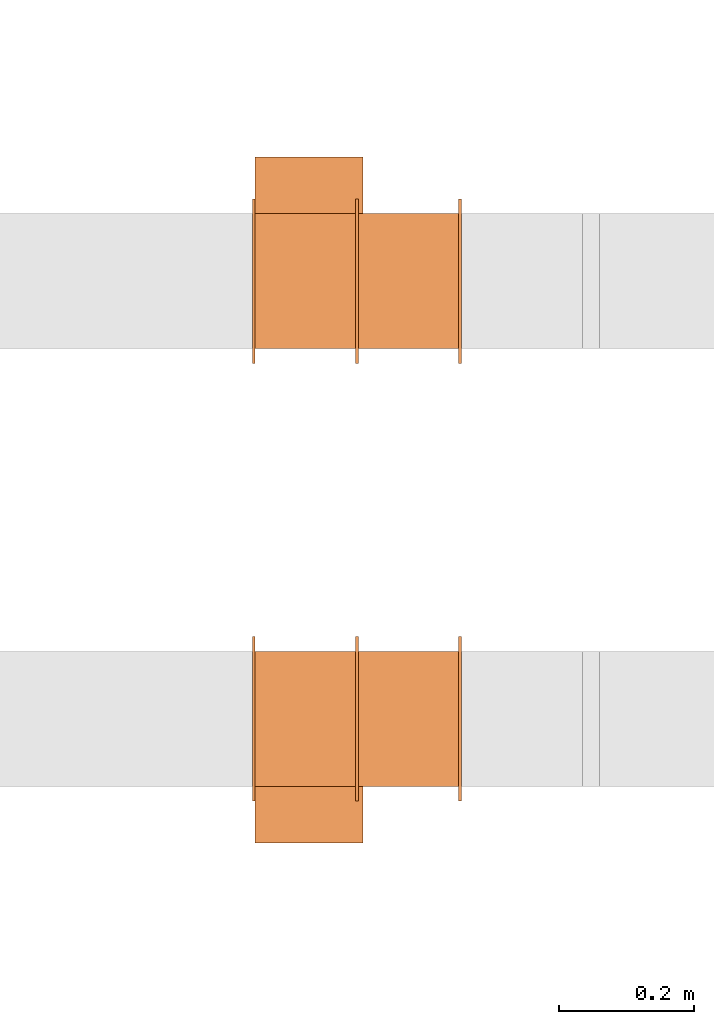
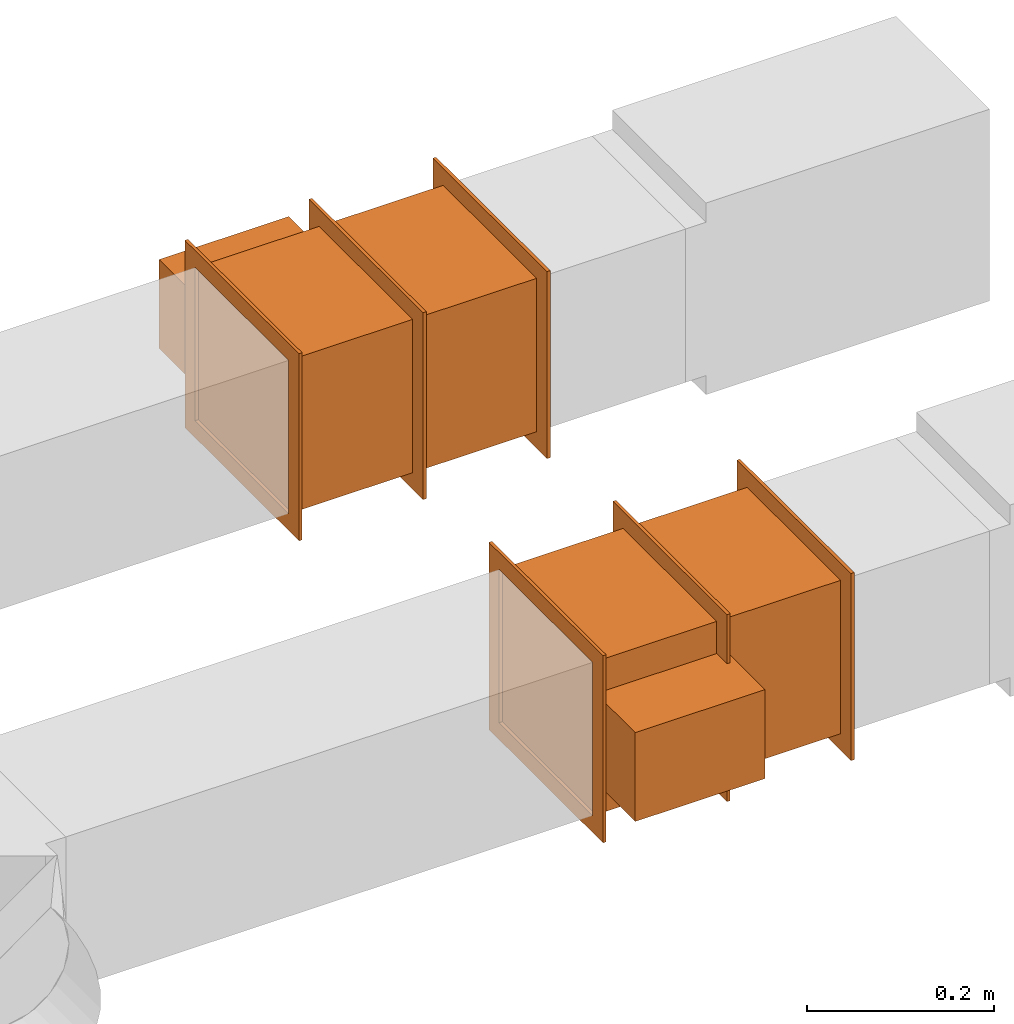
# One storey, part 12 of 12: 2 proxies.
"""IFC2X3 building model written with IfcOpenShell, lengths in millimetres."""

from ifc_helpers import new_model, entity, si_unit, converted_unit, derived_unit, direction, frame, frame_2d, origin, origin_2d_with_axis, place, context, subcontext, project, spatial, polyline, rectangle, outline, extrude, source, transform, mapped, type_object, type_shapes, element, save


model = new_model("IFC2X3")

# Units and contexts
model_context = context("Model", 3, precision=0.01, world=origin(), true_north=direction((6.12303176911189e-17, 1.0)))
body_context = subcontext(model_context, "Body", "Model", "MODEL_VIEW")
ifc_project = project(units=[si_unit("LENGTHUNIT", "METRE", prefix="MILLI"), si_unit("AREAUNIT", "SQUARE_METRE"), si_unit("VOLUMEUNIT", "CUBIC_METRE"), converted_unit("PLANEANGLEUNIT", "DEGREE", entity("IfcRatioMeasure", 0.0174532925199433), si_unit("PLANEANGLEUNIT", "RADIAN"), dimensions=[0, 0, 0, 0, 0, 0, 0]), si_unit("MASSUNIT", "GRAM", prefix="KILO"), derived_unit("MASSDENSITYUNIT", [(si_unit("MASSUNIT", "GRAM", prefix="KILO"), 1), (si_unit("LENGTHUNIT", "METRE"), -3)]), si_unit("TIMEUNIT", "SECOND"), si_unit("FREQUENCYUNIT", "HERTZ"), si_unit("THERMODYNAMICTEMPERATUREUNIT", "DEGREE_CELSIUS"), derived_unit("THERMALTRANSMITTANCEUNIT", [(si_unit("MASSUNIT", "GRAM", prefix="KILO"), 1), (si_unit("THERMODYNAMICTEMPERATUREUNIT", "KELVIN"), -1), (si_unit("TIMEUNIT", "SECOND"), -3)]), derived_unit("VOLUMETRICFLOWRATEUNIT", [(si_unit("LENGTHUNIT", "METRE"), 3), (si_unit("TIMEUNIT", "SECOND"), -1)]), si_unit("ELECTRICCURRENTUNIT", "AMPERE"), si_unit("ELECTRICVOLTAGEUNIT", "VOLT"), si_unit("POWERUNIT", "WATT"), si_unit("FORCEUNIT", "NEWTON", prefix="KILO"), si_unit("ILLUMINANCEUNIT", "LUX"), si_unit("LUMINOUSFLUXUNIT", "LUMEN"), si_unit("LUMINOUSINTENSITYUNIT", "CANDELA"), derived_unit("USERDEFINED", [(si_unit("MASSUNIT", "GRAM", prefix="KILO"), -1), (si_unit("LENGTHUNIT", "METRE"), -2), (si_unit("TIMEUNIT", "SECOND"), 3), (si_unit("LUMINOUSFLUXUNIT", "LUMEN"), 1)]), derived_unit("LINEARVELOCITYUNIT", [(si_unit("LENGTHUNIT", "METRE"), 1), (si_unit("TIMEUNIT", "SECOND"), -1)]), si_unit("PRESSUREUNIT", "PASCAL"), derived_unit("USERDEFINED", [(si_unit("LENGTHUNIT", "METRE"), -2), (si_unit("MASSUNIT", "GRAM", prefix="KILO"), 1), (si_unit("TIMEUNIT", "SECOND"), -2)])], contexts=[model_context])

# Site, building, storey
site_placement = place(None, origin())
site = spatial("IfcSite", under=ifc_project, at=site_placement, CompositionType="ELEMENT")
building_placement = place(site_placement, origin())
building = spatial("IfcBuilding", under=site, at=building_placement, CompositionType="ELEMENT")
storey_placement = place(building_placement, frame((0.0, 0.0, 8000.0)))
storey = spatial("IfcBuildingStorey", under=building, at=storey_placement, Name="02 Level", CompositionType="ELEMENT", Elevation=8000.0)

# Proxies
building_element_proxy_type_1 = type_object("IfcBuildingElementProxyType", Name="WK", PredefinedType="NOTDEFINED")
shared_shape_1 = source(origin(), body_context, "Body", "SweptSolid", [
    extrude(outline(polyline([(-122.0, -122.0), (122.0, -122.0), (122.0, 122.0), (-122.0, 122.0), (-122.0, -122.0)]), holes=[polyline([(-100.0, -100.0), (-100.0, 100.0), (100.0, 100.0), (100.0, -100.0), (-100.0, -100.0)])]), frame((151.0, 0.0, 0.0), z_axis=(1.0, 0.0, 0.0), x_axis=(0.0, 0.0, -1.0)), (0.0, 0.0, 1.0), 4.0),
    extrude(outline(polyline([(-122.0, -122.0), (122.0, -122.0), (122.0, 122.0), (-122.0, 122.0), (-122.0, -122.0)]), holes=[polyline([(-100.0, -100.0), (-100.0, 100.0), (100.0, 100.0), (100.0, -100.0), (-100.0, -100.0)])]), frame((-155.0, 0.0, 0.0), z_axis=(1.0, 0.0, 0.0), x_axis=(0.0, -1.0, 0.0)), (0.0, 0.0, 1.0), 4.0),
    extrude(outline(polyline([(-122.0, -122.0), (122.0, -122.0), (122.0, 122.0), (-122.0, 122.0), (-122.0, -122.0)]), holes=[polyline([(-100.0, -100.0), (-100.0, 100.0), (100.0, 100.0), (100.0, -100.0), (-100.0, -100.0)])]), frame((-2.0, 0.0, 0.0), z_axis=(1.0, 0.0, 0.0), x_axis=(0.0, -1.0, 0.0)), (0.0, 0.0, 1.0), 4.0),
    extrude(rectangle(XDim=302.0, YDim=200.0, at=origin_2d_with_axis()), frame((0.0, 0.0, -100.0), z_axis=(0.0, 0.0, 1.0), x_axis=(-1.0, 0.0, 0.0)), (0.0, 0.0, 1.0), 200.0),
    extrude(rectangle(XDim=84.0, YDim=160.0, at=frame_2d((-1.06581410364015e-14, 0.0), x_axis=(1.0, 0.0))), frame((71.0, -142.0, -58.0), z_axis=(0.0, 0.0, 1.0), x_axis=(0.0, -1.0, 0.0)), (0.0, 0.0, 1.0), 116.0),
])
type_shapes(building_element_proxy_type_1, [shared_shape_1])
proxy_1_placement = place(storey_placement, frame((24095.9900708518, -69156.0352293172, 3000.0), z_axis=(0.0, 0.0, -1.0), x_axis=(-1.0, 0.0, 0.0)))
element("IfcBuildingElementProxy", 1, at=proxy_1_placement, inside=storey, type_object=building_element_proxy_type_1, Name="WK25-0001:WK", ObjectType="WK25-0001:WK", context=body_context, shape_type="MappedRepresentation", body=[
    mapped(shared_shape_1, transform((0.0, 0.0, 0.0), scale=1.0)),
])
building_element_proxy_type_2 = type_object("IfcBuildingElementProxyType", Name="WK", PredefinedType="NOTDEFINED")
shared_shape_2 = source(origin(), body_context, "Body", "SweptSolid", [
    extrude(outline(polyline([(-122.0, -122.0), (122.0, -122.0), (122.0, 122.0), (-122.0, 122.0), (-122.0, -122.0)]), holes=[polyline([(-100.0, -100.0), (-100.0, 100.0), (100.0, 100.0), (100.0, -100.0), (-100.0, -100.0)])]), frame((151.0, 0.0, 0.0), z_axis=(1.0, 0.0, 0.0), x_axis=(0.0, -1.0, 0.0)), (0.0, 0.0, 1.0), 4.0),
    extrude(outline(polyline([(-122.0, -122.0), (122.0, -122.0), (122.0, 122.0), (-122.0, 122.0), (-122.0, -122.0)]), holes=[polyline([(-100.0, -100.0), (-100.0, 100.0), (100.0, 100.0), (100.0, -100.0), (-100.0, -100.0)])]), frame((-155.0, 0.0, 0.0), z_axis=(1.0, 0.0, 0.0), x_axis=(0.0, 0.0, -1.0)), (0.0, 0.0, 1.0), 4.0),
    extrude(outline(polyline([(-122.0, -122.0), (122.0, -122.0), (122.0, 122.0), (-122.0, 122.0), (-122.0, -122.0)]), holes=[polyline([(-100.0, -100.0), (-100.0, 100.0), (100.0, 100.0), (100.0, -100.0), (-100.0, -100.0)])]), frame((-2.0, 0.0, 0.0), z_axis=(1.0, 0.0, 0.0), x_axis=(0.0, 0.0, -1.0)), (0.0, 0.0, 1.0), 4.0),
    extrude(rectangle(XDim=200.0, YDim=302.0, at=origin_2d_with_axis()), frame((0.0, 0.0, -100.0), z_axis=(0.0, 0.0, 1.0), x_axis=(0.0, 1.0, 0.0)), (0.0, 0.0, 1.0), 200.0),
    extrude(rectangle(XDim=160.0, YDim=84.0, at=frame_2d((0.0, -1.06581410364015e-14), x_axis=(1.0, 0.0))), frame((71.0, 142.0, -58.0)), (0.0, 0.0, 1.0), 116.0),
])
type_shapes(building_element_proxy_type_2, [shared_shape_2])
proxy_2_placement = place(storey_placement, frame((24095.9900708518, -68506.4439409626, 3000.0), z_axis=(0.0, 0.0, -1.0), x_axis=(-1.0, 0.0, 0.0)))
element("IfcBuildingElementProxy", 2, at=proxy_2_placement, inside=storey, type_object=building_element_proxy_type_2, Name="WK25-0001:WK", ObjectType="WK25-0001:WK", context=body_context, shape_type="MappedRepresentation", body=[
    mapped(shared_shape_2, transform((0.0, 0.0, 0.0), scale=1.0)),
])

save(model, "model.ifc")
